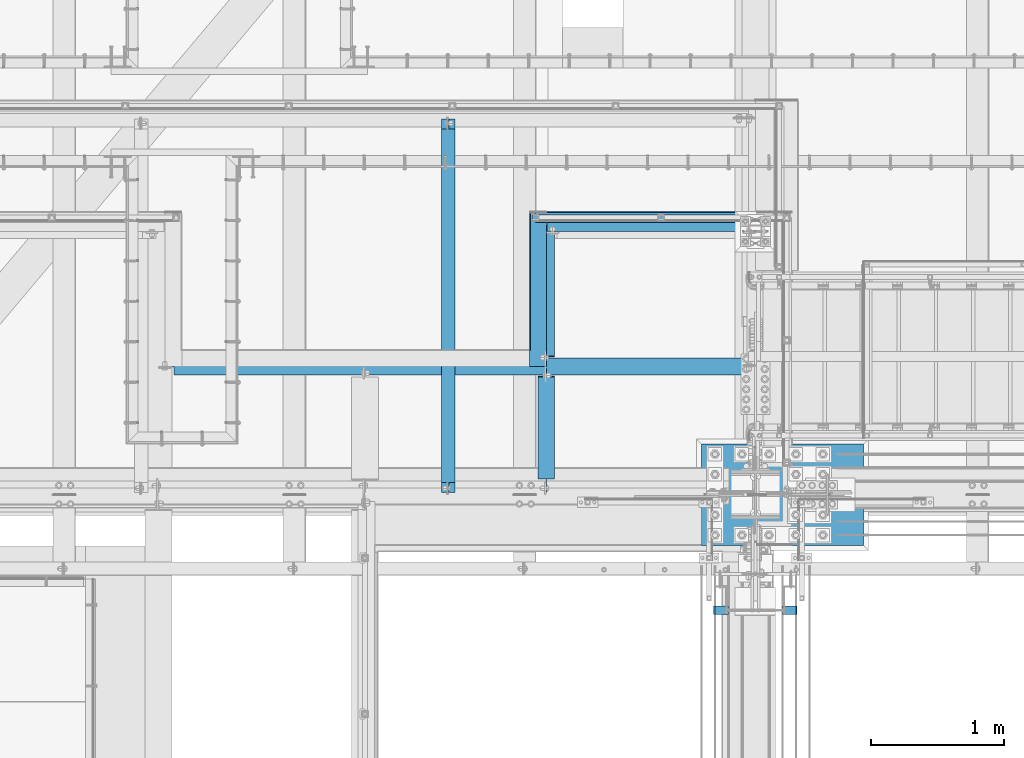
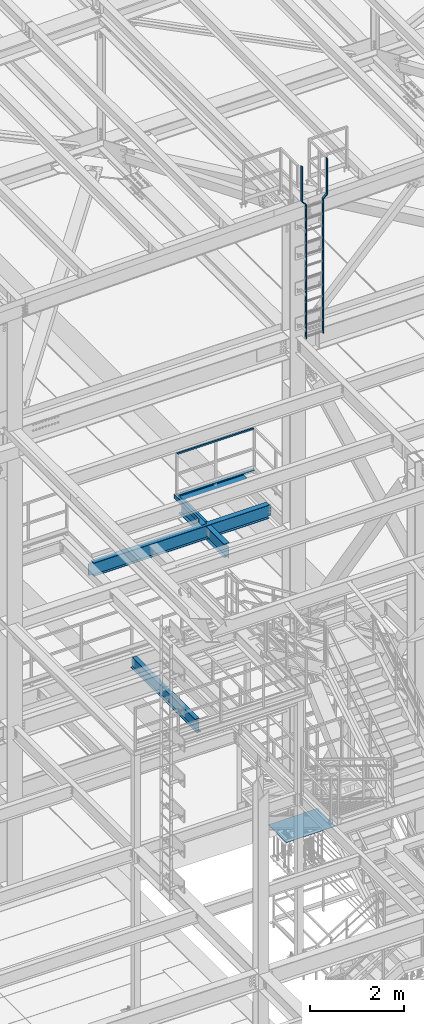
# One storey, part 1785 of 3843: 11 beams, 9 elements without a shape of their own.
"""IFC2X3 building model written with IfcOpenShell, lengths in millimetres."""

import ifcopenshell
import ifcopenshell.guid

model = None  # the IFC model being written
_history = None  # IfcOwnerHistory: only IFC2X3 demands one
_inside = {}  # id of a spatial element -> (the spatial element, [elements in it])
_under = {}  # id of a project, library or spatial element -> (it, [spatial elements below it])
_declared = {}  # id of a project -> (the project, [libraries it declares])
_typed = {}  # id of a type object -> (the type object, [elements of that type])
_made_of = {}  # id of a material, layer set ... -> (it, [elements and type objects made of it])


def new_model(schema):
    """Start an empty IFC model of exactly this schema.

    Asked for "IFC4X3", IfcOpenShell would pick the latest addendum, in which some entities
    have other attributes; the version numbers below select the first issue.
    IFC2X3 requires an IfcOwnerHistory on every rooted entity: one is made here for all.
    """
    global model, _history
    if schema == "IFC4X3":
        model = ifcopenshell.file(schema_version=(4, 3, 0, 0))
    else:
        model = ifcopenshell.file(schema=schema)
    _inside.clear()
    _under.clear()
    _declared.clear()
    _typed.clear()
    _made_of.clear()
    _history = None
    if model.schema == "IFC2X3":
        org = make("IfcOrganization", Name="unknown")
        user = make(
            "IfcPersonAndOrganization",
            ThePerson=make("IfcPerson", FamilyName="unknown"),
            TheOrganization=org,
        )
        app = make(
            "IfcApplication",
            ApplicationDeveloper=org,
            Version="unknown",
            ApplicationFullName="unknown",
            ApplicationIdentifier="unknown",
        )
        _history = make(
            "IfcOwnerHistory",
            OwningUser=user,
            OwningApplication=app,
            ChangeAction="ADDED",
            CreationDate=0,
        )
    return model


def make(cls, **values):
    """One entity of the class cls with the attributes given. An attribute that is None is left unset."""
    return model.create_entity(
        cls, **{name: value for name, value in values.items() if value is not None}
    )


def rooted(cls, **values):
    """An entity with a GlobalId (a new one), such as an element, a storey or a relation."""
    return make(cls, GlobalId=ifcopenshell.guid.new(), OwnerHistory=_history, **values)


def si_unit(unit_type, name, prefix=None):
    """IfcSIUnit, for example si_unit("LENGTHUNIT", "METRE", prefix="MILLI")."""
    return make("IfcSIUnit", UnitType=unit_type, Prefix=prefix, Name=name)


def assignment(units):
    """IfcUnitAssignment: the units of a project."""
    return None if units is None else make("IfcUnitAssignment", Units=units)


def point(xyz):
    """IfcCartesianPoint."""
    return None if xyz is None else make("IfcCartesianPoint", Coordinates=xyz)


def direction(xyz):
    """IfcDirection."""
    return None if xyz is None else make("IfcDirection", DirectionRatios=xyz)


def frame(location, z_axis=None, x_axis=None):
    """IfcAxis2Placement3D, a coordinate frame: its origin and axes. An axis left out is left unset."""
    return make(
        "IfcAxis2Placement3D",
        Location=point(location),
        Axis=direction(z_axis),
        RefDirection=direction(x_axis),
    )


def origin_with_axes():
    """The frame at (0, 0, 0) with the z axis (0, 0, 1) and the x axis (1, 0, 0) written out."""
    return frame((0.0, 0.0, 0.0), z_axis=(0.0, 0.0, 1.0), x_axis=(1.0, 0.0, 0.0))


def place(relative_to, where):
    """IfcLocalPlacement: puts the frame where relative to a parent placement (None: the world)."""
    return make(
        "IfcLocalPlacement", PlacementRelTo=relative_to, RelativePlacement=where
    )


def context(
    kind, dimensions, precision=None, world=None, true_north=None, identifier=None
):
    """IfcGeometricRepresentationContext, for example the 3D "Model" context."""
    return make(
        "IfcGeometricRepresentationContext",
        ContextIdentifier=identifier,
        ContextType=kind,
        CoordinateSpaceDimension=dimensions,
        Precision=precision,
        WorldCoordinateSystem=world,
        TrueNorth=true_north,
    )


def subcontext(parent, identifier, kind, view, scale=None):
    """IfcGeometricRepresentationSubContext, for example "Body" below "Model"."""
    return make(
        "IfcGeometricRepresentationSubContext",
        ContextIdentifier=identifier,
        ContextType=kind,
        ParentContext=parent,
        TargetScale=scale,
        TargetView=view,
    )


def project(units=None, contexts=None):
    """IfcProject with its units and contexts."""
    return rooted(
        "IfcProject",
        Name="project",
        RepresentationContexts=contexts,
        UnitsInContext=assignment(units),
    )


def spatial(cls, under=None, at=None, **own):
    """A site, building, storey or space (cls), placed at a placement, below another one or the project."""
    s = rooted(cls, ObjectPlacement=at, **own)
    if under is not None:
        _under.setdefault(under.id(), (under, []))[1].append(s)
    return s


def faces_of(points, faces, orient=None, outer=None):
    """IfcFace entities. A face is a list of loops; a loop is a list of indices into points, from 0.

    orient and outer hold one flag for each loop. By default every Orientation is true, the
    first loop of a face is its IfcFaceOuterBound and the others are IfcFaceBound.
    """
    made = []
    for i, loops in enumerate(faces):
        bounds = []
        for j, loop in enumerate(loops):
            is_outer = j == 0 if outer is None else outer[i][j]
            bounds.append(
                make(
                    "IfcFaceOuterBound" if is_outer else "IfcFaceBound",
                    Bound=make("IfcPolyLoop", Polygon=[points[k] for k in loop]),
                    Orientation=True if orient is None else orient[i][j],
                )
            )
        made.append(make("IfcFace", Bounds=bounds))
    return made


def faceted_brep(points, faces, orient=None, outer=None, voids=None):
    """IfcFacetedBrep: a solid bounded by flat faces; with voids (closed shells), ...WithVoids."""
    shared = [point(p) for p in points]
    hull = make("IfcClosedShell", CfsFaces=faces_of(shared, faces, orient, outer))
    if voids is None:
        return make("IfcFacetedBrep", Outer=hull)
    return make(
        "IfcFacetedBrepWithVoids",
        Outer=hull,
        Voids=[
            make(cls, CfsFaces=faces_of(shared, fs, o, b)) for cls, fs, o, b in voids
        ],
    )


def shape(context_of_items, identifier, shape_type, items):
    """IfcShapeRepresentation: the items that make up one representation, for example the "Body"."""
    return make(
        "IfcShapeRepresentation",
        ContextOfItems=context_of_items,
        RepresentationIdentifier=identifier,
        RepresentationType=shape_type,
        Items=items,
    )


def material(Name=None, Category=None):
    """IfcMaterial."""
    return make("IfcMaterial", Name=Name, Category=Category)


def made_of(thing, what):
    """Note that an element or type object is made of a material, layer set ...; save() writes the relation."""
    if what is not None:
        _made_of.setdefault(what.id(), (what, []))[1].append(thing)
    return thing


def type_object(cls, material=None, **own):
    """A type object (cls), such as IfcWallType, which elements share."""
    return made_of(rooted(cls, **own), material)


def element(
    cls,
    number,
    at=None,
    inside=None,
    cuts=None,
    type_object=None,
    material=None,
    context=None,
    identifier="Body",
    shape_type=None,
    held_by="IfcProductDefinitionShape",
    body=None,
    shapes=None,
    **own,
):
    """One element of the class cls, such as IfcWall. Its Tag is "e" and its number.

    at: its placement. inside: the storey or other place that contains it. cuts: it is an
    opening in that element (IfcRelVoidsElement). A single representation is given by context,
    identifier, shape_type and body (its items); several are given by shapes. held_by: the class
    of the entity that holds the representations. save() writes the other relations.
    """
    e = rooted(cls, Tag="e%d" % number, ObjectPlacement=at, **own)
    if body is not None:
        shapes = [shape(context, identifier, shape_type, body)]
    if shapes is not None:
        e.Representation = make(held_by, Representations=shapes)
    if inside is not None:
        _inside.setdefault(inside.id(), (inside, []))[1].append(e)
    if cuts is not None:
        rooted(
            "IfcRelVoidsElement", RelatingBuildingElement=cuts, RelatedOpeningElement=e
        )
    if type_object is not None:
        _typed.setdefault(type_object.id(), (type_object, []))[1].append(e)
    return made_of(e, material)


def aggregate(whole, parts):
    """IfcRelAggregates: a whole, such as a stair, and the parts it consists of."""
    return rooted("IfcRelAggregates", RelatingObject=whole, RelatedObjects=parts)


def save(model, path):
    """Write the relations noted so far, then the file.

    IfcRelAggregates (storeys below a building ...), IfcRelContainedInSpatialStructure (elements
    in a storey), IfcRelDefinesByType, IfcRelAssociatesMaterial and IfcRelDeclares: one each for
    every whole, place, type object, material and project.
    """
    for whole, parts in _under.values():
        aggregate(whole, parts)
    for where, things in _inside.values():
        rooted(
            "IfcRelContainedInSpatialStructure",
            RelatedElements=things,
            RelatingStructure=where,
        )
    for kind, things in _typed.values():
        rooted("IfcRelDefinesByType", RelatedObjects=things, RelatingType=kind)
    for what, things in _made_of.values():
        rooted("IfcRelAssociatesMaterial", RelatedObjects=things, RelatingMaterial=what)
    for by, libraries in _declared.values():
        rooted("IfcRelDeclares", RelatingContext=by, RelatedDefinitions=libraries)
    model.write(path)


model = new_model("IFC2X3")

# Units and contexts
model_context = context("Model", 3, precision=1e-05, world=origin_with_axes())
body_context = subcontext(model_context, "Body", "Model", "MODEL_VIEW")
ifc_project = project(units=[si_unit("LENGTHUNIT", "METRE", prefix="MILLI"), si_unit("AREAUNIT", "SQUARE_METRE"), si_unit("VOLUMEUNIT", "CUBIC_METRE"), si_unit("MASSUNIT", "GRAM", prefix="KILO"), si_unit("TIMEUNIT", "SECOND"), si_unit("PLANEANGLEUNIT", "RADIAN"), si_unit("SOLIDANGLEUNIT", "STERADIAN"), si_unit("THERMODYNAMICTEMPERATUREUNIT", "DEGREE_CELSIUS"), si_unit("LUMINOUSINTENSITYUNIT", "LUMEN")], contexts=[model_context])

# Site, building, storey
site_placement = place(None, origin_with_axes())
site = spatial("IfcSite", under=ifc_project, at=site_placement, CompositionType="ELEMENT")
building_placement = place(site_placement, origin_with_axes())
building = spatial("IfcBuilding", under=site, at=building_placement, Name="Undefined", CompositionType="ELEMENT")
storey_placement = place(building_placement, origin_with_axes())
storey = spatial("IfcBuildingStorey", under=building, at=storey_placement, Name="Undefined", CompositionType="ELEMENT", Elevation=0.0)

# Assembly, beam
assembly_1_placement = place(storey_placement, origin_with_axes())
assembly_1 = element("IfcElementAssembly", 1, at=assembly_1_placement, inside=storey, Name="RAIL", AssemblyPlace="NOTDEFINED", PredefinedType="RIGID_FRAME")
ifc_material_1 = material()
beam_type_1 = type_object("IfcBeamType", Name="HSS1-1/2X1-1/2X1/4", PredefinedType="NOTDEFINED")
beam_1_placement = place(assembly_1_placement, frame((56165.750012207, 27701.8747862042, 38633.3999983618), z_axis=(0.0, 0.0, -1.0), x_axis=(-1.0, 0.0, 0.0)))
beam_1 = element("IfcBeam", 2, at=beam_1_placement, type_object=beam_type_1, material=ifc_material_1, Name="RAIL", ObjectType="HSS1-1/2X1-1/2X1/4", context=body_context, shape_type="Brep", body=[
    faceted_brep([(19.0499992350015, 12.6999993299978, -12.6999993299978), (19.0499992350015, -12.6999993299978, -12.6999993299978), (1905.00001153701, -12.6999993300014, -12.6999993299978), (1905.00001153701, 12.6999993300014, -12.6999993299978), (19.0499992350015, -12.6999993299978, 12.6999993299978), (1879.60001287702, -12.6999993300014, 12.6999993299978), (19.0499992350015, 12.6999993299978, 12.6999993299978), (1879.60001287702, 12.6999993300014, 12.6999993299978), (19.0499992350015, 19.0499992350015, -19.0499992350015), (19.0499992350015, 19.0499992350015, 19.0499992350015), (1873.25001297201, 19.0499992350015, 19.0499992350015), (1911.35001144202, 19.0499992350015, -19.0499992350015), (19.0499992350015, -19.0499992350015, 19.0499992350015), (1873.25001297201, -19.0499992350015, 19.0499992350015), (19.0499992350015, -19.0499992350015, -19.0499992350015), (1911.35001144202, -19.0499992350015, -19.0499992350015)], [[[0, 1, 2, 3]], [[1, 4, 5, 2]], [[4, 6, 7, 5]], [[6, 0, 3, 7]], [[8, 9, 10, 11]], [[9, 12, 13, 10]], [[12, 14, 15, 13]], [[14, 8, 11, 15]], [[13, 15, 11, 10], [5, 7, 3, 2]], [[14, 12, 9, 8], [6, 4, 1, 0]]]),
])
aggregate(assembly_1, [beam_1])

assembly_2_placement = place(storey_placement, origin_with_axes())
assembly_2 = element("IfcElementAssembly", 3, at=assembly_2_placement, inside=storey, Name="ref.", AssemblyPlace="NOTDEFINED", PredefinedType="RIGID_FRAME")
ifc_material_2 = material(Name="STEEL/Steel_Undefined")
beam_type_2 = type_object("IfcBeamType", PredefinedType="NOTDEFINED")
beam_2_placement = place(assembly_2_placement, frame((54273.45, 27701.8747862042, 37563.4249983618), z_axis=(0.0, -1.0, 0.0), x_axis=(1.0, 0.0, 0.0)))
beam_2 = element("IfcBeam", 4, at=beam_2_placement, type_object=beam_type_2, material=ifc_material_2, Name="ref.", context=body_context, shape_type="Brep", body=[
    faceted_brep([(0.0, 3.17500000000291, -38.0999999999985), (0.0, 3.17500000000291, 38.0999999999985), (1892.30001220702, 3.17500000000291, 38.0999999999985), (1892.30001220702, 3.17500000000291, -38.0999999999985), (0.0, -3.17500000000291, 38.0999999999985), (1892.30001220702, -3.17500000000291, 38.0999999999985), (0.0, -3.17500000000291, -38.0999999999985), (1892.30001220702, -3.17500000000291, -38.0999999999985)], [[[0, 1, 2, 3]], [[1, 4, 5, 2]], [[4, 6, 7, 5]], [[6, 0, 3, 7]], [[5, 7, 3, 2]], [[6, 4, 1, 0]]]),
])
aggregate(assembly_2, [beam_2])

# Assembly, beams
assembly_3_placement = place(storey_placement, origin_with_axes())
assembly_3 = element("IfcElementAssembly", 5, at=assembly_3_placement, inside=storey, AssemblyPlace="NOTDEFINED", PredefinedType="RIGID_FRAME")
ifc_material_3 = material(Name="STEEL/A36")
beam_type_3 = type_object("IfcBeamType", PredefinedType="NOTDEFINED")
beam_3_placement = place(assembly_3_placement, frame((55722.8375000005, 24745.9500000003, 42904.2092601983), z_axis=(0.0, 1.0, 0.0), x_axis=(0.0, 0.0, 1.0)))
beam_3 = element("IfcBeam", 6, at=beam_3_placement, type_object=beam_type_3, material=ifc_material_3, context=body_context, shape_type="Brep", body=[
    faceted_brep([(0.0, -4.76249999999709, -31.75), (0.0, -4.76249999999709, 31.75), (0.0, 4.76249999999709, 31.75), (0.0, 4.76249999999709, -31.75), (3476.19073980171, 4.76249999999709, 31.75), (3476.19073980171, 4.76249999999709, -31.75), (3472.24535562011, -4.76249999999709, -31.75), (3472.24535562011, -4.76249999999709, 31.75), (3577.79073980171, -96.8375000000087, 31.75), (3577.79073980171, -96.8375000000087, -31.75), (3573.84535562011, -106.362500000003, -31.75), (3573.84535562011, -106.362500000003, 31.75), (4492.19073980169, -96.8375000000087, 31.75), (4492.19073980169, -96.8375000000087, -31.75), (4492.19073980169, -106.362500000003, 31.75), (4492.19073980169, -106.362500000003, -31.75)], [[[0, 1, 2, 3]], [[3, 2, 4, 5]], [[1, 0, 6, 7]], [[5, 4, 8, 9]], [[7, 6, 10, 11]], [[9, 8, 12, 13]], [[8, 4, 2, 1, 7, 11, 14, 12]], [[11, 10, 15, 14]], [[10, 6, 0, 3, 5, 9, 13, 15]], [[14, 15, 13, 12]]]),
])
beam_4_placement = place(assembly_3_placement, frame((56240.3625000005, 24745.9500000003, 47396.4), z_axis=(0.0, 1.0, 0.0), x_axis=(0.0, 0.0, -1.0)))
beam_4 = element("IfcBeam", 7, at=beam_4_placement, type_object=beam_type_3, material=ifc_material_3, context=body_context, shape_type="Brep", body=[
    faceted_brep([(0.0, -4.76249999999709, -31.75), (0.0, -4.76249999999709, 31.75), (0.0, 4.76249999999709, 31.75), (0.0, 4.76249999999709, -31.75), (914.39999999998, 4.76249999999709, 31.75), (914.39999999998, 4.76249999999709, -31.75), (918.345384181579, -4.76249999999709, -31.75), (918.345384181579, -4.76249999999709, 31.75), (1015.99999999999, 106.362500000003, 31.75), (1015.99999999999, 106.362500000003, -31.75), (1019.94538418158, 96.8375000000087, -31.75), (1019.94538418158, 96.8375000000087, 31.75), (4492.19073980169, 106.362500000003, 31.75), (4492.19073980169, 106.362500000003, -31.75), (4492.19073980169, 96.8375000000087, 31.75), (4492.19073980169, 96.8375000000087, -31.75)], [[[0, 1, 2, 3]], [[3, 2, 4, 5]], [[1, 0, 6, 7]], [[5, 4, 8, 9]], [[7, 6, 10, 11]], [[9, 8, 12, 13]], [[8, 4, 2, 1, 7, 11, 14, 12]], [[11, 10, 15, 14]], [[10, 6, 0, 3, 5, 9, 13, 15]], [[14, 15, 13, 12]]]),
])
aggregate(assembly_3, [beam_3, beam_4])

# Assembly, beam
assembly_4_placement = place(storey_placement, origin_with_axes())
assembly_4 = element("IfcElementAssembly", 8, at=assembly_4_placement, inside=storey, Name="BEAM", AssemblyPlace="NOTDEFINED", PredefinedType="RIGID_FRAME")
ifc_material_4 = material(Name="STEEL/A992")
beam_type_4 = type_object("IfcBeamType", Name="W12X19", PredefinedType="NOTDEFINED")
beam_5_placement = place(assembly_4_placement, frame((53619.4, 25615.8999999464, 33043.8124999995), z_axis=(0.0, 0.0, 1.0), x_axis=(0.0, 1.0, 0.0)))
beam_5 = element("IfcBeam", 9, at=beam_5_placement, type_object=beam_type_4, material=ifc_material_4, Name="BEAM", ObjectType="W12X19", context=body_context, shape_type="Brep", body=[
    faceted_brep([(2751.93125005356, -50.8000000000029, 153.987500000003), (2751.93125005356, -50.8000000000029, 144.462500000001), (2751.93125005356, -3.17500000000291, 144.462500000001), (2751.93125005356, -3.17500000000291, 141.287499809274), (2751.93125005356, 3.17500000000291, 141.287499809274), (2751.93125005356, 3.17500000000291, 144.462500000001), (2751.93125005356, 50.8000000000029, 144.462500000001), (2751.93125005356, 50.8000000000029, 153.987500000003), (2752.89797997615, -3.17500000000291, 136.427420291227), (2752.89797997615, 3.17500000000291, 136.427420291227), (2755.65099387663, -3.17500000000291, 132.307243823074), (2755.65099387663, 3.17500000000291, 132.307243823074), (2759.77117034478, -3.17500000000291, 129.5542299226), (2759.77117034478, 3.17500000000291, 129.5542299226), (2764.63124986283, -3.17500000000291, 128.587500000009), (2764.63124986283, 3.17500000000291, 128.587500000009), (2828.13125005356, -3.17500000000291, 128.587500000009), (2828.13125005356, 3.17500000000291, 128.587500000009), (92.8687499999796, -50.8000000000002, 153.987499810319), (92.8687499999796, 50.8000000000002, 153.987500000003), (92.8687499999796, 50.8000000000002, 144.462500000001), (92.8687499999796, 3.17500000000018, 144.462500000001), (92.8687499999796, 3.17500000000018, 141.287499809259), (92.8687499999796, -3.17500000000018, 141.287499809259), (92.8687499999796, -3.17500000000018, 144.462500000001), (92.8687499999796, -50.8000000000002, 144.462500000001), (91.9020200773957, 3.17500000000018, 136.427420291213), (91.9020200773957, -3.17500000000018, 136.427420291213), (89.1490061769146, 3.17500000000018, 132.307243823059), (89.1490061769146, -3.17500000000018, 132.307243823059), (85.0288297087536, 3.17500000000018, 129.554229922585), (85.0288297087536, -3.17500000000018, 129.554229922585), (80.1687501907145, 3.17500000000018, 128.587499999994), (80.1687501907145, -3.17500000000018, 128.587499999994), (16.6687499999971, 3.17499999999927, 128.587500000001), (16.6687499999971, -3.17499999999927, 128.587500000001), (16.6687499999971, 3.17499999999927, 115.887499999742), (16.6687499999971, 3.17499999999927, -114.712500000256), (16.6687499999971, 3.17499999999927, -144.462500000001), (16.6687499999971, 50.7999999999993, -144.462500000001), (16.6687499999971, 50.7999999999993, -153.987500000003), (16.6687499999971, -50.7999999999993, -153.987500000003), (16.6687499999971, -50.7999999999993, -144.462500000001), (16.6687499999971, -3.17499999999927, -144.462500000001), (2828.13125005356, 3.17500000000291, -144.462500000001), (2828.13125005356, 50.8000000000029, -144.462500000001), (2828.13125005356, 50.8000000000029, -153.987500000003), (2828.13125005356, -50.8000000000029, -153.987500000003), (2828.13125005356, -50.8000000000029, -144.462500000001), (2828.13125005356, -3.17500000000291, -144.462500000001), (2828.13125005356, 3.17500000000291, 115.887499999997), (2828.13125005356, 3.17500000000291, -114.712500000001)], [[[0, 1, 2, 3, 4, 5, 6, 7]], [[8, 9, 4, 3]], [[10, 11, 9, 8]], [[12, 13, 11, 10]], [[14, 15, 13, 12]], [[16, 17, 15, 14]], [[18, 19, 20, 21, 22, 23, 24, 25]], [[23, 22, 26, 27]], [[27, 26, 28, 29]], [[29, 28, 30, 31]], [[31, 30, 32, 33]], [[33, 32, 34, 35]], [[36, 37, 38, 39, 40, 41, 42, 43, 35, 34]], [[39, 38, 44, 45]], [[40, 39, 45, 46]], [[41, 40, 46, 47]], [[42, 41, 47, 48]], [[43, 42, 48, 49]], [[12, 10, 8, 3, 2, 24, 23, 27, 29, 31, 33, 35, 43, 49, 16, 14]], [[25, 24, 2, 1]], [[18, 25, 1, 0]], [[19, 18, 0, 7]], [[20, 19, 7, 6]], [[21, 20, 6, 5]], [[50, 51, 44, 38, 37, 36, 34, 32, 30, 28, 26, 22, 21, 5, 4, 9, 11, 13, 15, 17]], [[49, 48, 47, 46, 45, 44, 51, 50, 17, 16]]]),
])
aggregate(assembly_4, [beam_5])

assembly_5_placement = place(storey_placement, origin_with_axes())
assembly_5 = element("IfcElementAssembly", 10, at=assembly_5_placement, inside=storey, Name="BEAM", AssemblyPlace="NOTDEFINED", PredefinedType="RIGID_FRAME")
beam_type_5 = type_object("IfcBeamType", PredefinedType="NOTDEFINED")
beam_6_placement = place(assembly_5_placement, frame((54356.0, 27163.7125, 37468.175), z_axis=(0.0, -1.0, 0.0), x_axis=(-1.0, 0.0, 0.0)))
beam_6 = element("IfcBeam", 11, at=beam_6_placement, type_object=beam_type_5, material=ifc_material_3, Name="BENT_PLATE", context=body_context, shape_type="Brep", body=[
    faceted_brep([(127.000000000007, -98.4249984741255, 461.962499999991), (127.000000000007, -3.17500000001019, 461.962499999991), (120.650000000001, -3.17500000000291, 461.962499999991), (120.650000000001, -98.4249984741255, 461.962499999991), (127.000000000007, -3.17500000001019, 582.612499999992), (120.650000000001, -3.17500000000291, 582.612499999999), (120.650000000001, -3.17500000000291, -582.612499999999), (0.0, -3.17500000000291, -582.612499999999), (0.0, 3.17500000000291, -582.612499999999), (127.000000000007, 3.17500000000291, -582.612499999999), (127.000000000007, -98.4249984741255, -582.612499999999), (120.650000000001, -98.4249984741255, -582.612499999999), (0.0, -3.17500000000291, 461.962499999991), (0.0, -3.17500000000291, 582.612499999999), (0.0, 3.17500000000291, 582.612499999999), (127.000000000007, 3.17500000000291, 582.612499999999)], [[[0, 1, 2, 3]], [[4, 5, 2, 1]], [[6, 7, 8, 9, 10, 11]], [[7, 12, 13, 14, 8]], [[8, 14, 15, 9]], [[0, 10, 9, 15, 4, 1]], [[11, 10, 0, 3]], [[6, 11, 3, 2]], [[13, 12, 7, 6, 2, 5]], [[15, 14, 13, 5, 4]]]),
])

assembly_6_placement = place(storey_placement, origin_with_axes())
assembly_6 = element("IfcElementAssembly", 12, at=assembly_6_placement, inside=storey, Name="BEAM", AssemblyPlace="NOTDEFINED", PredefinedType="RIGID_FRAME")
beam_type_6 = type_object("IfcBeamType", PredefinedType="NOTDEFINED")
beam_7_placement = place(assembly_6_placement, frame((55149.75, 27597.1, 37468.175), z_axis=(-1.0, 0.0, 0.0), x_axis=(0.0, 1.0, 0.0)))
beam_7 = element("IfcBeam", 13, at=beam_7_placement, type_object=beam_type_6, material=ifc_material_3, Name="BENT_PLATE", context=body_context, shape_type="Brep", body=[
    faceted_brep([(0.0, -3.17500000000291, -787.400000000001), (0.0, -3.17500000000291, 787.400000000001), (0.0, 3.17500000000291, 787.400000000001), (0.0, 3.17500000000291, -787.400000000001), (149.224999999995, 3.17500000000291, 787.400000000001), (149.224999999995, 3.17500000000291, -787.400000000001), (142.874999999996, -3.17500000000291, -787.400000000001), (142.874999999996, -3.17500000000291, 787.400000000001), (149.224999999995, -98.4249999999956, 787.400000000001), (149.224999999995, -98.4249999999956, -787.400000000001), (142.874999999996, -98.4249999999956, 787.400000000001), (142.874999999996, -98.4249999999956, -787.400000000001)], [[[0, 1, 2, 3]], [[3, 2, 4, 5]], [[1, 0, 6, 7]], [[5, 4, 8, 9]], [[4, 2, 1, 7, 10, 8]], [[7, 6, 11, 10]], [[6, 0, 3, 5, 9, 11]], [[10, 11, 9, 8]]]),
])
aggregate(assembly_6, [beam_7])

assembly_7_placement = place(storey_placement, origin_with_axes())
assembly_7 = element("IfcElementAssembly", 14, at=assembly_7_placement, inside=storey, Name="BEAM", AssemblyPlace="NOTDEFINED", PredefinedType="RIGID_FRAME")
beam_type_7 = type_object("IfcBeamType", Name="W14X22", PredefinedType="NOTDEFINED")
beam_8_placement = place(assembly_7_placement, frame((54356.0, 25615.9, 37290.375), z_axis=(0.0, 0.0, 1.0), x_axis=(0.0, 1.0, 0.0)))
beam_8 = element("IfcBeam", 15, at=beam_8_placement, type_object=beam_type_7, material=ifc_material_4, Name="BEAM", ObjectType="W14X22", context=body_context, shape_type="Brep", body=[
    faceted_brep([(16.668750000008, -3.17500000000291, -149.224999999999), (16.668750000008, 3.17500000000291, -149.224999999999), (105.568750190745, 3.17500000000291, -149.224999999999), (105.568750190745, -3.17500000000291, -149.224999999999), (110.428829708791, 3.17500000000291, -150.19172992259), (110.428829708791, -3.17500000000291, -150.19172992259), (114.549006176945, 3.17500000000291, -152.944743823064), (114.549006176945, -3.17500000000291, -152.944743823064), (117.302020077423, 3.17500000000291, -157.064920291217), (117.302020077423, -3.17500000000291, -157.064920291217), (118.26875000001, -3.17500000000291, -161.924999809264), (118.26875000001, 3.17500000000291, -161.924999809264), (118.26875000001, 3.17500000000291, -166.6875), (118.26875000001, 63.5, -166.6875), (118.26875000001, 63.5, -174.625), (118.26875000001, -63.5, -174.625), (118.26875000001, -63.5, -166.6875), (118.26875000001, -3.17500000000291, -166.6875), (887.592407499371, 63.5, 174.625), (892.17501058014, 63.5, 166.6875), (118.268750000007, 63.5, 166.6875), (118.268750000007, 63.5, 174.625), (892.17501058014, 3.17500000000291, 166.6875), (118.268750000007, 3.17500000000291, 166.6875), (105.568750190741, -3.17500000000291, 149.224999999999), (105.568750190741, 3.17500000000291, 149.224999999999), (16.668750000008, 3.17500000000291, 149.224999999999), (16.668750000008, -3.17500000000291, 149.224999999999), (110.428829708788, -3.17500000000291, 150.19172992259), (110.428829708788, 3.17500000000291, 150.19172992259), (114.549006176941, -3.17500000000291, 152.944743823064), (114.549006176941, 3.17500000000291, 152.944743823064), (117.302020077419, -3.17500000000291, 157.064920291217), (117.302020077419, 3.17500000000291, 157.064920291217), (118.268750000007, -3.17500000000291, 161.924999809264), (118.268750000007, 3.17500000000291, 161.924999809264), (892.17501058014, -63.5, 166.6875), (887.592407499371, -63.5, 174.625), (118.268750000007, -63.5, 174.624999813313), (118.268750000007, -63.5, 166.6875), (892.17501058014, -3.17500000000291, 166.6875), (118.268750000007, -3.17500000000291, 166.6875), (892.404213191869, -3.17500000000291, 166.290499496463), (892.404213191869, 3.17500000000291, 166.290499496463), (879.474998474128, -3.17500000000291, 166.290499496463), (879.474998474128, 3.17500000000291, 166.290499496463), (851.700903806734, -3.17500000000291, 156.63426542349), (851.700903806734, 3.17500000000291, 156.63426542349), (847.391386535917, -3.17500000000291, 153.588154120938), (847.391386535917, 3.17500000000291, 153.588154120938), (845.364992992305, -3.17500000000291, 148.715325129342), (845.364992992305, 3.17500000000291, 148.715325129342), (846.243780620094, -3.17500000000291, 143.511627839893), (846.243780620094, 3.17500000000291, 143.511627839893), (849.757981294799, -3.17500000000291, 139.57448080265), (849.757981294799, 3.17500000000291, 139.57448080265), (854.828814096978, -3.17500000000291, 138.112500000003), (854.828814096978, 3.17500000000291, 138.112500000003), (949.325000000008, -3.17500000000291, 138.112500000003), (949.325000000008, 3.17500000000291, 138.112500000003), (949.325000000008, -3.17500000000291, -138.112500000003), (949.325000000008, 3.17500000000291, -138.112500000003), (856.137812143854, -3.17500000000291, -138.112500000003), (856.137812143854, 3.17500000000291, -138.112500000003), (851.066979341675, -3.17500000000291, -139.57448080265), (851.066979341675, 3.17500000000291, -139.57448080265), (847.55277866697, -3.17500000000291, -143.511627839893), (847.55277866697, 3.17500000000291, -143.511627839893), (846.673991039181, -3.17500000000291, -148.715325129342), (846.673991039181, 3.17500000000291, -148.715325129342), (848.700384582793, -3.17500000000291, -153.588154120938), (848.700384582793, 3.17500000000291, -153.588154120938), (853.009901853609, -3.17500000000291, -156.63426542349), (853.009901853609, 3.17500000000291, -156.63426542349), (880.783996521004, -3.17500000000291, -166.290499496463), (880.783996521004, 3.17500000000291, -166.290499496463), (887.363187545241, -3.17500000000291, -166.290499496463), (887.363187545241, 3.17500000000291, -166.290499496463), (892.174632762351, -63.5, -174.625), (892.174632762351, 63.5, -174.625), (887.592372986303, 63.5, -166.6875), (887.592372986303, 3.17500000000291, -166.6875), (887.592372986303, -3.17500000000291, -166.6875), (887.592372986303, -63.5, -166.6875), (16.668750000008, 3.17500000000291, -94.0749999999971), (16.668750000008, 3.17500000000291, 136.525000000001)], [[[0, 1, 2, 3]], [[3, 2, 4, 5]], [[5, 4, 6, 7]], [[7, 6, 8, 9]], [[10, 11, 12, 13, 14, 15, 16, 17]], [[9, 8, 11, 10]], [[18, 19, 20, 21]], [[19, 22, 23, 20]], [[24, 25, 26, 27]], [[28, 29, 25, 24]], [[30, 31, 29, 28]], [[32, 33, 31, 30]], [[34, 35, 33, 32]], [[36, 37, 38, 39]], [[40, 36, 39, 41]], [[38, 21, 20, 23, 35, 34, 41, 39]], [[37, 18, 21, 38]], [[36, 40, 42, 43, 22, 19, 18, 37]], [[44, 45, 43, 42]], [[46, 47, 45, 44]], [[48, 49, 47, 46]], [[50, 51, 49, 48]], [[52, 53, 51, 50]], [[54, 55, 53, 52]], [[56, 57, 55, 54]], [[57, 56, 58, 59]], [[58, 60, 61, 59]], [[62, 63, 61, 60]], [[64, 65, 63, 62]], [[66, 67, 65, 64]], [[68, 69, 67, 66]], [[70, 71, 69, 68]], [[72, 73, 71, 70]], [[74, 75, 73, 72]], [[75, 74, 76, 77]], [[78, 79, 80, 81, 77, 76, 82, 83]], [[83, 82, 17, 16]], [[78, 83, 16, 15]], [[79, 78, 15, 14]], [[80, 79, 14, 13]], [[81, 80, 13, 12]], [[6, 4, 2, 1, 84, 85, 26, 25, 29, 31, 33, 35, 23, 22, 43, 45, 47, 49, 51, 53, 55, 57, 59, 61, 63, 65, 67, 69, 71, 73, 75, 77, 81, 12, 11, 8]], [[27, 26, 85, 84, 1, 0]], [[82, 76, 74, 72, 70, 68, 66, 64, 62, 60, 58, 56, 54, 52, 50, 48, 46, 44, 42, 40, 41, 34, 32, 30, 28, 24, 27, 0, 3, 5, 7, 9, 10, 17]]]),
])
aggregate(assembly_7, [beam_8])

# Beam
beam_9_placement = place(assembly_5_placement, frame((54356.0, 26581.1, 37290.375), z_axis=(0.0, 0.0, 1.0), x_axis=(0.0, 1.0, 0.0)))
beam_9 = element("IfcBeam", 16, at=beam_9_placement, type_object=beam_type_7, material=ifc_material_4, Name="BEAM", ObjectType="W14X22", context=body_context, shape_type="Brep", body=[
    faceted_brep([(77.6075925006371, -63.5, 174.625), (77.6075925006371, 63.5, 174.625), (73.0249894198678, 63.5, 166.6875), (73.0249894198678, 3.17500000000291, 166.6875), (72.7957868081394, 3.17500000000291, 166.290499496463), (72.7957868081394, -3.17500000000291, 166.290499496463), (73.0249894198678, -3.17500000000291, 166.6875), (73.0249894198678, -63.5, 166.6875), (85.7250015258796, -3.17500000000291, 166.290499496463), (85.7250015258796, 3.17500000000291, 166.290499496463), (113.499096193274, 3.17500000000291, 156.63426542349), (113.499096193274, -3.17500000000291, 156.63426542349), (117.808613464091, 3.17500000000291, 153.588154120938), (117.808613464091, -3.17500000000291, 153.588154120938), (119.835007007703, 3.17500000000291, 148.715325129342), (119.835007007703, -3.17500000000291, 148.715325129342), (118.956219379914, 3.17500000000291, 143.511627839893), (118.956219379914, -3.17500000000291, 143.511627839893), (115.442018705209, 3.17500000000291, 139.57448080265), (115.442018705209, -3.17500000000291, 139.57448080265), (110.37118590303, 3.17500000000291, 138.112500000003), (110.37118590303, -3.17500000000291, 138.112500000003), (15.875, 3.17500000000291, 138.112500000003), (15.875, -3.17500000000291, 138.112500000003), (15.875, 3.17500000000291, -138.112500000003), (15.875, -3.17500000000291, -138.112500000003), (109.062187856154, 3.17500000000291, -138.112500000003), (109.062187856154, -3.17500000000291, -138.112500000003), (114.133020658333, 3.17500000000291, -139.57448080265), (114.133020658333, -3.17500000000291, -139.57448080265), (117.647221333038, 3.17500000000291, -143.511627839893), (117.647221333038, -3.17500000000291, -143.511627839893), (118.526008960827, 3.17500000000291, -148.715325129342), (118.526008960827, -3.17500000000291, -148.715325129342), (116.499615417215, 3.17500000000291, -153.588154120938), (116.499615417215, -3.17500000000291, -153.588154120938), (112.190098146399, 3.17500000000291, -156.63426542349), (112.190098146399, -3.17500000000291, -156.63426542349), (84.4160034790038, 3.17500000000291, -166.290499496463), (84.4160034790038, -3.17500000000291, -166.290499496463), (77.8368124547669, 3.17500000000291, -166.290499496463), (77.8368124547669, -3.17500000000291, -166.290499496463), (1066.8, 3.17500000000291, -166.6875), (1066.8, 63.5, -166.6875), (77.6076270137055, 63.5, -166.6875), (77.6076270137055, 3.17500000000291, -166.6875), (1066.8, 63.5, -174.625), (1066.8, -63.5, -174.625), (73.0253672376566, -63.5, -174.625), (73.0253672376566, 63.5, -174.625), (1066.8, -63.5, -166.6875), (77.6076270137055, -63.5, -166.6875), (1066.8, -3.17500000000291, -166.6875), (77.6076270137055, -3.17500000000291, -166.6875), (1066.8, 3.17500000000291, 166.6875), (1066.8, 63.5, 166.6875), (1066.8, 63.5, 174.625), (1066.8, -63.5, 174.625), (1066.8, -63.5, 166.6875), (1066.8, -3.17500000000291, 166.6875)], [[[0, 1, 2, 3, 4, 5, 6, 7]], [[8, 9, 10, 11]], [[11, 10, 12, 13]], [[13, 12, 14, 15]], [[15, 14, 16, 17]], [[17, 16, 18, 19]], [[19, 18, 20, 21]], [[21, 20, 22, 23]], [[23, 22, 24, 25]], [[26, 27, 25, 24]], [[27, 26, 28, 29]], [[29, 28, 30, 31]], [[31, 30, 32, 33]], [[33, 32, 34, 35]], [[35, 34, 36, 37]], [[37, 36, 38, 39]], [[39, 38, 40, 41]], [[42, 43, 44, 45]], [[46, 47, 48, 49]], [[47, 50, 51, 48]], [[50, 52, 53, 51]], [[41, 40, 45, 44, 49, 48, 51, 53]], [[43, 46, 49, 44]], [[42, 54, 55, 56, 57, 58, 59, 52, 50, 47, 46, 43]], [[58, 57, 0, 7]], [[59, 58, 7, 6]], [[8, 11, 13, 15, 17, 19, 21, 23, 25, 27, 29, 31, 33, 35, 37, 39, 41, 53, 52, 59, 6, 5]], [[9, 8, 5, 4]], [[54, 42, 45, 40, 38, 36, 34, 32, 30, 28, 26, 24, 22, 20, 18, 16, 14, 12, 10, 9, 4, 3]], [[55, 54, 3, 2]], [[56, 55, 2, 1]], [[57, 56, 1, 0]]]),
])

aggregate(assembly_5, [beam_6, beam_9])

# Assembly, beam
assembly_8_placement = place(storey_placement, origin_with_axes())
assembly_8 = element("IfcElementAssembly", 17, at=assembly_8_placement, inside=storey, Name="BEAM", AssemblyPlace="NOTDEFINED", PredefinedType="RIGID_FRAME")
beam_10_placement = place(assembly_8_placement, frame((51435.0, 26581.1, 37290.375), z_axis=(0.0, 0.0, 1.0), x_axis=(1.0, 0.0, 0.0)))
beam_10 = element("IfcBeam", 18, at=beam_10_placement, type_object=beam_type_7, material=ifc_material_4, Name="BEAM", ObjectType="W14X22", context=body_context, shape_type="Brep", body=[
    faceted_brep([(4416.425, -3.17499999999927, -166.6875), (4416.425, -63.5, -166.6875), (4416.425, -63.5, -174.625), (4416.425, 63.5, -174.625), (4416.425, 63.5, -166.6875), (4416.425, 3.17499999999927, -166.6875), (4416.425, 3.17499999999927, -161.924999809264), (4416.425, -3.17499999999927, -161.924999809264), (4417.39172992259, 3.17499999999927, -157.064920291217), (4417.39172992259, -3.17499999999927, -157.064920291217), (4420.14474382307, 3.17499999999927, -152.944743823064), (4420.14474382307, -3.17499999999927, -152.944743823064), (4424.26492029122, 3.17499999999927, -150.19172992259), (4424.26492029122, -3.17499999999927, -150.19172992259), (4429.12499980927, 3.17499999999927, -149.224999999999), (4429.12499980927, -3.17499999999927, -149.224999999999), (4479.925, -3.17499999999927, -149.224999999999), (4479.925, 3.17499999999927, -149.224999999999), (118.268750000007, 3.17500000000291, 166.6875), (118.268750000007, 63.5, 166.6875), (4416.425, 63.5, 166.6875), (4416.425, 3.17499999999927, 166.6875), (118.268749999996, -3.17499999999927, -162.184999809266), (118.268749999996, 3.17499999999927, -162.184999809266), (118.26875000001, 3.17500000000291, -166.6875), (118.26875000001, 63.5, -166.6875), (118.26875000001, 63.5, -174.625), (118.26875000001, -63.5, -174.625), (118.26875000001, -63.5, -166.6875), (118.26875000001, -3.17500000000291, -166.6875), (117.302020077404, -3.17499999999927, -157.324920291219), (117.302020077404, 3.17499999999927, -157.324920291219), (114.549006176931, -3.17499999999927, -153.204743823066), (114.549006176931, 3.17499999999927, -153.204743823066), (110.428829708777, -3.17499999999927, -150.451729922592), (110.428829708777, 3.17499999999927, -150.451729922592), (105.56875019073, -3.17499999999927, -149.485000000001), (105.56875019073, 3.17499999999927, -149.485000000001), (16.6687500000044, -3.17499999999927, -149.485000000001), (16.6687500000044, 3.17499999999927, -149.485000000001), (16.6687500000044, -3.17499999999927, 148.965001678465), (16.6687500000044, 3.17499999999927, 148.965001678465), (105.56875019073, -3.17499999999927, 148.965001678465), (105.56875019073, 3.17499999999927, 148.965001678465), (110.428829708777, -3.17499999999927, 149.931731601057), (110.428829708777, 3.17499999999927, 149.931731601057), (114.549006176931, -3.17499999999927, 152.68474550153), (114.549006176931, 3.17499999999927, 152.68474550153), (117.302020077404, -3.17499999999927, 156.804921969684), (117.302020077404, 3.17499999999927, 156.804921969684), (118.268749999996, -3.17499999999927, 161.66500148773), (118.268749999996, 3.17499999999927, 161.66500148773), (118.268750000007, -63.5, 174.624999813313), (118.268750000007, 63.5, 174.625), (118.268750000007, -3.17500000000291, 166.6875), (118.268750000007, -63.5, 166.6875), (4416.425, -3.17499999999927, 166.6875), (4416.425, -63.5, 166.6875), (4416.425, -63.5, 174.624999997235), (4416.425, 63.5, 174.625), (4416.425, -3.17499999999927, 161.924999809264), (4416.425, 3.17499999999927, 161.924999809264), (4417.39172992259, -3.17499999999927, 157.064920291217), (4417.39172992259, 3.17499999999927, 157.064920291217), (4420.14474382307, -3.17499999999927, 152.944743823064), (4420.14474382307, 3.17499999999927, 152.944743823064), (4424.26492029122, -3.17499999999927, 150.19172992259), (4424.26492029122, 3.17499999999927, 150.19172992259), (4429.12499980927, -3.17499999999927, 149.224999999999), (4429.12499980927, 3.17499999999927, 149.224999999999), (4479.925, -3.17499999999927, 149.224999999999), (4479.925, 3.17499999999927, 149.224999999999), (4479.925, 3.17499999999927, -94.0749999999971), (4479.925, 3.17499999999927, 136.525000000001)], [[[0, 1, 2, 3, 4, 5, 6, 7]], [[7, 6, 8, 9]], [[9, 8, 10, 11]], [[11, 10, 12, 13]], [[13, 12, 14, 15]], [[16, 15, 14, 17]], [[18, 19, 20, 21]], [[22, 23, 24, 25, 26, 27, 28, 29]], [[30, 31, 23, 22]], [[32, 33, 31, 30]], [[34, 35, 33, 32]], [[36, 37, 35, 34]], [[38, 39, 37, 36]], [[40, 41, 39, 38]], [[42, 43, 41, 40]], [[44, 45, 43, 42]], [[46, 47, 45, 44]], [[48, 49, 47, 46]], [[50, 51, 49, 48]], [[52, 53, 19, 18, 51, 50, 54, 55]], [[55, 54, 56, 57]], [[52, 55, 57, 58]], [[53, 52, 58, 59]], [[19, 53, 59, 20]], [[58, 57, 56, 60, 61, 21, 20, 59]], [[62, 63, 61, 60]], [[64, 65, 63, 62]], [[66, 67, 65, 64]], [[68, 69, 67, 66]], [[70, 71, 69, 68]], [[72, 73, 71, 70, 16, 17]], [[12, 10, 8, 6, 5, 24, 23, 31, 33, 35, 37, 39, 41, 43, 45, 47, 49, 51, 18, 21, 61, 63, 65, 67, 69, 71, 73, 72, 17, 14]], [[25, 24, 5, 4]], [[26, 25, 4, 3]], [[27, 26, 3, 2]], [[28, 27, 2, 1]], [[29, 28, 1, 0]], [[70, 68, 66, 64, 62, 60, 56, 54, 50, 48, 46, 44, 42, 40, 38, 36, 34, 32, 30, 22, 29, 0, 7, 9, 11, 13, 15, 16]]]),
])
aggregate(assembly_8, [beam_10])

assembly_9_placement = place(storey_placement, origin_with_axes())
assembly_9 = element("IfcElementAssembly", 19, at=assembly_9_placement, inside=storey, Name="TEMPLATE", AssemblyPlace="NOTDEFINED", PredefinedType="RIGID_FRAME")
ifc_material_5 = material(Name="STEEL/A572-50")
beam_type_8 = type_object("IfcBeamType", PredefinedType="NOTDEFINED")
beam_11_placement = place(assembly_9_placement, frame((56134.0, 25234.8999938965, 29608.4625), z_axis=(-1.0, 0.0, 0.0), x_axis=(0.0, 1.0, 0.0)))
beam_11 = element("IfcBeam", 20, at=beam_11_placement, type_object=beam_type_8, material=ifc_material_5, Name="TEMPLATE", context=body_context, shape_type="Brep", body=[
    faceted_brep([(0.0, 4.76250000000073, -609.599999999999), (0.0, 4.76250000000073, 609.599999999999), (762.00001220702, 4.76250000000073, 609.599999999999), (762.00001220702, 4.76250000000073, -609.599999999999), (0.0, -4.76250000000073, 609.599999999999), (762.00001220702, -4.76250000000073, 609.599999999999), (0.0, -4.76250000000073, -609.599999999999), (762.00001220702, -4.76250000000073, -609.599999999999)], [[[0, 1, 2, 3]], [[1, 4, 5, 2]], [[4, 6, 7, 5]], [[6, 0, 3, 7]], [[5, 7, 3, 2]], [[6, 4, 1, 0]]]),
])
aggregate(assembly_9, [beam_11])

save(model, "model.ifc")
